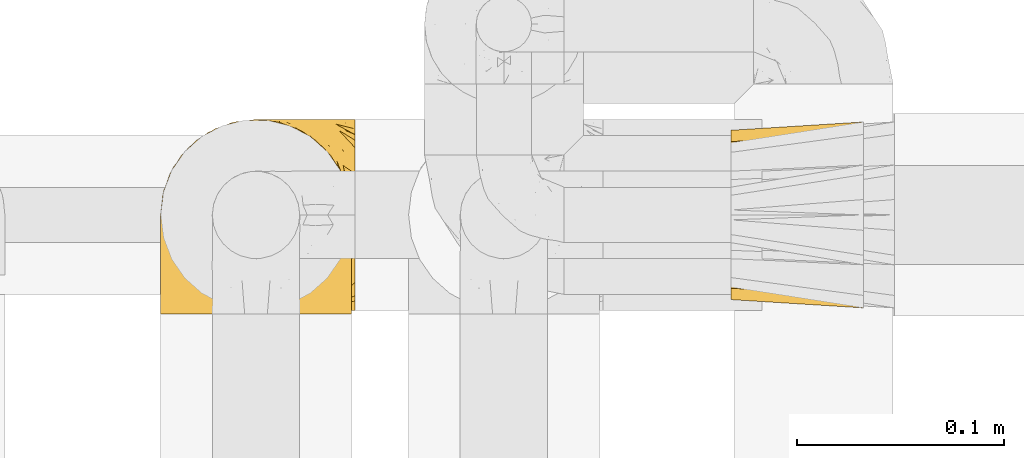
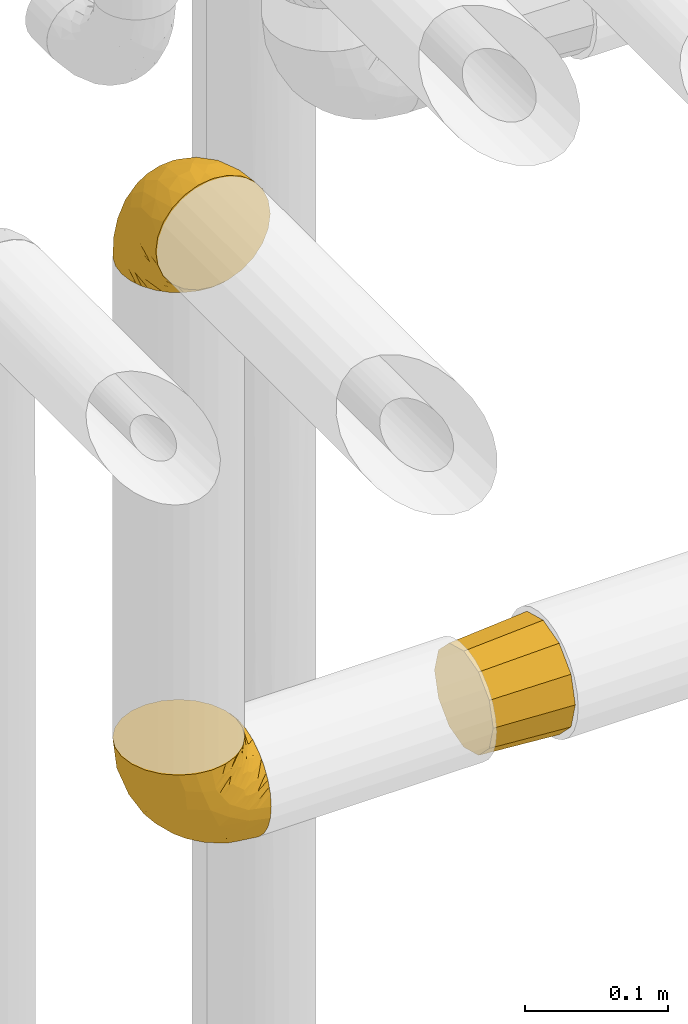
# One storey, part 431 of 827: 3 coverings.
"""IFC2X3 building model written with IfcOpenShell, lengths in millimetres."""

from ifc_helpers import new_model, entity, si_unit, converted_unit, derived_unit, direction, frame, origin, place, context, subcontext, project, spatial, faceted_brep, element, save


model = new_model("IFC2X3")

# Units and contexts
model_context = context("Model", 3, precision=0.01, world=origin(), true_north=direction((6.12303176911189e-17, 1.0)))
body_context = subcontext(model_context, "Body", "Model", "MODEL_VIEW")
ifc_project = project(units=[si_unit("LENGTHUNIT", "METRE", prefix="MILLI"), si_unit("AREAUNIT", "SQUARE_METRE"), si_unit("VOLUMEUNIT", "CUBIC_METRE"), converted_unit("PLANEANGLEUNIT", "DEGREE", entity("IfcRatioMeasure", 0.0174532925199433), si_unit("PLANEANGLEUNIT", "RADIAN"), dimensions=[0, 0, 0, 0, 0, 0, 0]), si_unit("MASSUNIT", "GRAM", prefix="KILO"), derived_unit("MASSDENSITYUNIT", [(si_unit("MASSUNIT", "GRAM", prefix="KILO"), 1), (si_unit("LENGTHUNIT", "METRE"), -3)]), derived_unit("MOMENTOFINERTIAUNIT", [(si_unit("LENGTHUNIT", "METRE"), 4)]), si_unit("TIMEUNIT", "SECOND"), si_unit("FREQUENCYUNIT", "HERTZ"), si_unit("THERMODYNAMICTEMPERATUREUNIT", "DEGREE_CELSIUS"), derived_unit("THERMALTRANSMITTANCEUNIT", [(si_unit("MASSUNIT", "GRAM", prefix="KILO"), 1), (si_unit("THERMODYNAMICTEMPERATUREUNIT", "KELVIN"), -1), (si_unit("TIMEUNIT", "SECOND"), -3)]), derived_unit("VOLUMETRICFLOWRATEUNIT", [(si_unit("LENGTHUNIT", "METRE"), 3), (si_unit("TIMEUNIT", "SECOND"), -1)]), derived_unit("MASSFLOWRATEUNIT", [(si_unit("MASSUNIT", "GRAM", prefix="KILO"), 1), (si_unit("TIMEUNIT", "SECOND"), -1)]), derived_unit("ROTATIONALFREQUENCYUNIT", [(si_unit("TIMEUNIT", "SECOND"), -1)]), si_unit("ELECTRICCURRENTUNIT", "AMPERE"), si_unit("ELECTRICVOLTAGEUNIT", "VOLT"), si_unit("POWERUNIT", "WATT"), si_unit("FORCEUNIT", "NEWTON", prefix="KILO"), si_unit("ILLUMINANCEUNIT", "LUX"), si_unit("LUMINOUSFLUXUNIT", "LUMEN"), si_unit("LUMINOUSINTENSITYUNIT", "CANDELA"), derived_unit("USERDEFINED", [(si_unit("MASSUNIT", "GRAM", prefix="KILO"), -1), (si_unit("LENGTHUNIT", "METRE"), -2), (si_unit("TIMEUNIT", "SECOND"), 3), (si_unit("LUMINOUSFLUXUNIT", "LUMEN"), 1)]), derived_unit("LINEARVELOCITYUNIT", [(si_unit("LENGTHUNIT", "METRE"), 1), (si_unit("TIMEUNIT", "SECOND"), -1)]), si_unit("PRESSUREUNIT", "PASCAL"), derived_unit("USERDEFINED", [(si_unit("LENGTHUNIT", "METRE"), -2), (si_unit("MASSUNIT", "GRAM", prefix="KILO"), 1), (si_unit("TIMEUNIT", "SECOND"), -2)]), derived_unit("LINEARFORCEUNIT", [(si_unit("MASSUNIT", "GRAM", prefix="KILO"), 1), (si_unit("LENGTHUNIT", "METRE"), 1), (si_unit("TIMEUNIT", "SECOND"), -2), (si_unit("LENGTHUNIT", "METRE"), -1)]), derived_unit("PLANARFORCEUNIT", [(si_unit("MASSUNIT", "GRAM", prefix="KILO"), 1), (si_unit("LENGTHUNIT", "METRE"), 1), (si_unit("TIMEUNIT", "SECOND"), -2), (si_unit("LENGTHUNIT", "METRE"), -2)])], contexts=[model_context])

# Site, building, storey
site_placement = place(None, origin())
site = spatial("IfcSite", under=ifc_project, at=site_placement, CompositionType="ELEMENT")
building_placement = place(site_placement, origin())
building = spatial("IfcBuilding", under=site, at=building_placement, CompositionType="ELEMENT")
storey_placement = place(building_placement, frame((0.0, 0.0, 28200.0)))
storey = spatial("IfcBuildingStorey", under=building, at=storey_placement, Name="08", CompositionType="ELEMENT", Elevation=28200.0)

# Coverings
covering_1_placement = place(storey_placement, frame((54021.99, 17450.4, 2450.4)))
element("IfcCovering", 1, at=covering_1_placement, inside=storey, Name=":ADSK_", ObjectType=":ADSK_", PredefinedType="INSULATION", context=body_context, shape_type="Brep", body=[
    faceted_brep([(11.68, 78.41, 1.6), (19.0, 85.72, 1.6), (27.76, 91.22, 1.6), (37.52, 94.64, 1.6), (47.8, 95.8, 1.6), (58.08, 94.64, 1.6), (67.85, 91.22, 1.6), (76.61, 85.71, 1.6), (83.92, 78.39, 1.6), (89.42, 69.63, 1.6), (92.84, 59.87, 1.6), (94.0, 49.6, 1.6), (93.53, 45.45, 1.6), (93.18, 42.38, 1.6), (92.84, 39.31, 1.6), (91.13, 34.43, 1.6), (89.42, 29.54, 1.6), (86.66, 25.16, 1.6), (83.91, 20.78, 1.6), (80.25, 17.13, 1.6), (76.59, 13.47, 1.6), (67.83, 7.97, 1.6), (62.95, 6.26, 1.6), (58.07, 4.55, 1.6), (47.8, 3.4, 1.6), (37.51, 4.55, 1.6), (32.63, 6.26, 1.6), (27.74, 7.97, 1.6), (18.98, 13.48, 1.6), (15.33, 17.14, 1.6), (11.67, 20.8, 1.6), (8.92, 25.18, 1.6), (6.17, 29.56, 1.6), (4.46, 34.44, 1.6), (2.75, 39.32, 1.6), (2.41, 42.39, 1.6), (2.06, 45.45, 1.6), (1.6, 49.6, 1.6), (2.75, 59.88, 1.6), (6.17, 69.65, 1.6), (47.8, 1.6, 3.4), (59.75, 1.6, 4.97), (70.9, 1.6, 9.58), (75.68, 1.6, 13.26), (80.46, 1.6, 16.93), (84.13, 1.6, 21.71), (87.81, 1.6, 26.5), (90.11, 1.6, 32.07), (92.42, 1.6, 37.64), (92.9, 1.6, 41.25), (93.17, 1.6, 43.34), (93.45, 1.6, 45.42), (94.0, 1.6, 49.6), (92.42, 1.6, 61.55), (87.81, 1.6, 72.7), (80.46, 1.6, 82.26), (70.9, 1.6, 89.61), (59.75, 1.6, 94.22), (47.8, 1.6, 95.8), (35.84, 1.6, 94.22), (24.7, 1.6, 89.61), (15.13, 1.6, 82.26), (7.78, 1.6, 72.7), (3.17, 1.6, 61.55), (1.6, 1.6, 49.6), (2.14, 1.6, 45.42), (2.69, 1.6, 41.25), (3.17, 1.6, 37.64), (5.48, 1.6, 32.07), (7.78, 1.6, 26.5), (11.46, 1.6, 21.71), (15.13, 1.6, 16.93), (19.91, 1.6, 13.26), (24.7, 1.6, 9.58), (35.84, 1.6, 4.97), (23.61, 36.81, 81.55), (31.99, 23.28, 90.4), (35.87, 45.8, 83.0), (47.8, 30.7, 91.18), (40.43, 21.2, 93.13), (47.8, 12.96, 94.0), (31.83, 66.19, 66.19), (23.37, 54.51, 70.92), (21.41, 17.98, 85.95), (3.07, 36.69, 49.74), (1.6, 35.54, 35.54), (1.6, 31.64, 38.14), (1.6, 27.75, 40.74), (1.6, 23.86, 43.34), (1.6, 19.96, 45.94), (13.45, 22.8, 77.59), (15.25, 42.67, 71.17), (8.07, 33.21, 65.81), (16.0, 59.45, 59.03), (17.34, 71.5, 45.85), (10.58, 62.66, 45.79), (5.34, 54.5, 41.42), (2.39, 47.57, 34.51), (8.36, 48.81, 56.04), (10.04, 74.98, 15.15), (2.59, 18.7, 56.51), (6.28, 15.75, 68.39), (34.28, 91.17, 23.33), (38.73, 85.28, 42.86), (27.25, 82.58, 39.42), (29.88, 75.78, 53.58), (38.6, 74.98, 59.17), (23.44, 67.27, 59.06), (25.25, 87.38, 22.63), (17.23, 82.04, 20.55), (47.8, 94.0, 12.96), (47.8, 77.8, 56.96), (47.8, 67.38, 67.38), (2.53, 56.2, 18.72), (1.6, 48.85, 5.33), (1.6, 48.11, 9.07), (1.6, 47.57, 11.79), (1.6, 47.03, 14.51), (1.6, 46.48, 17.24), (1.6, 45.94, 19.96), (5.71, 65.78, 21.03), (1.6, 17.24, 46.48), (1.6, 14.51, 47.03), (1.6, 11.79, 47.57), (1.6, 9.07, 48.11), (1.6, 7.2, 48.48), (1.6, 5.33, 48.85), (47.8, 91.18, 30.7), (1.6, 43.34, 23.86), (1.6, 40.74, 27.75), (1.6, 38.14, 31.64), (11.89, 72.73, 31.26), (47.8, 56.96, 77.8), (39.69, 62.23, 72.75), (47.8, 84.49, 43.83), (47.8, 43.83, 84.49), (13.84, 12.05, 14.58), (9.16, 18.95, 16.17), (15.79, 13.02, 10.82), (25.75, 8.34, 4.64), (16.09, 14.63, 7.71), (7.51, 11.09, 25.13), (3.99, 13.66, 32.66), (2.66, 20.08, 34.94), (3.16, 9.61, 36.76), (2.35, 9.48, 40.48), (2.23, 16.1, 39.25), (38.35, 3.42, 3.69), (6.18, 26.63, 13.99), (2.7, 33.72, 21.85), (2.93, 34.77, 17.93), (16.01, 6.75, 15.11), (9.08, 13.31, 21.14), (9.3, 21.11, 12.7), (11.68, 19.94, 7.21), (4.65, 8.67, 32.27), (3.65, 26.11, 25.68), (3.61, 29.3, 22.18), (12.8, 6.32, 18.79), (2.43, 39.92, 10.12), (6.83, 27.05, 9.47), (21.65, 6.04, 10.45), (3.7, 34.4, 11.29), (47.8, 2.87, 2.87), (3.37, 20.92, 31.16), (7.03, 27.43, 6.31), (7.87, 7.54, 25.62), (7.26, 18.45, 21.18), (3.41, 23.88, 28.81), (23.81, 7.77, 7.45), (86.5, 13.3, 21.14), (88.08, 11.09, 25.13), (82.79, 6.33, 18.79), (94.0, 9.07, 48.11), (94.0, 5.33, 48.85), (94.0, 14.51, 47.03), (94.0, 11.79, 47.57), (57.24, 3.42, 3.69), (71.76, 7.76, 7.44), (94.0, 47.03, 14.51), (94.0, 47.57, 11.79), (94.0, 48.85, 5.33), (94.0, 48.11, 9.07), (79.49, 14.62, 7.71), (88.75, 27.03, 9.47), (92.93, 20.08, 34.94), (92.22, 20.92, 31.16), (94.0, 27.75, 40.74), (94.0, 31.64, 38.14), (92.43, 9.61, 36.76), (93.24, 9.48, 40.48), (69.82, 8.33, 4.63), (79.57, 6.74, 15.11), (81.74, 12.04, 14.58), (94.0, 23.86, 43.34), (94.0, 19.96, 45.94), (93.36, 16.1, 39.25), (83.9, 19.93, 7.21), (86.28, 21.1, 12.69), (93.16, 39.92, 10.14), (92.88, 33.68, 21.81), (91.98, 29.28, 22.19), (89.41, 26.62, 14.0), (91.93, 26.08, 25.69), (86.42, 18.93, 16.17), (88.82, 27.87, 6.66), (92.66, 34.75, 17.92), (73.93, 6.04, 10.45), (94.0, 38.14, 31.64), (79.5, 12.79, 10.64), (91.89, 34.41, 11.31), (94.0, 45.94, 19.96), (94.0, 43.34, 23.86), (94.0, 40.74, 27.75), (91.6, 13.66, 32.66), (94.0, 17.24, 46.48), (90.94, 8.67, 32.27), (94.0, 35.54, 35.54), (92.16, 23.83, 28.77), (88.32, 18.43, 21.17), (86.13, 6.03, 23.36), (94.0, 46.48, 17.24), (93.2, 34.52, 47.58), (55.16, 21.2, 93.13), (82.02, 23.82, 77.44), (84.29, 41.32, 66.78), (76.94, 47.62, 71.68), (68.33, 52.66, 74.96), (71.98, 36.81, 81.55), (92.52, 49.75, 36.7), (92.9, 19.07, 56.9), (59.72, 45.8, 83.0), (63.6, 23.28, 90.4), (88.89, 21.35, 67.83), (74.18, 17.98, 85.95), (68.35, 82.57, 39.41), (61.33, 91.17, 23.33), (56.86, 85.27, 42.87), (68.62, 73.89, 53.92), (63.76, 66.19, 66.19), (72.19, 62.43, 64.12), (88.69, 63.53, 33.13), (92.19, 58.45, 23.1), (89.75, 67.16, 16.98), (59.86, 76.72, 55.72), (55.9, 62.22, 72.75), (77.99, 81.54, 23.77), (85.21, 74.8, 18.41), (74.99, 75.83, 43.7), (90.23, 41.45, 54.53), (70.75, 88.2, 17.73), (81.72, 71.6, 38.98), (86.53, 56.23, 50.28), (79.6, 59.44, 59.02)], [[[0, 1, 2, 3, 4, 5, 6, 7, 8, 9, 10, 11, 12, 13, 14, 15, 16, 17, 18, 19, 20, 21, 22, 23, 24, 25, 26, 27, 28, 29, 30, 31, 32, 33, 34, 35, 36, 37, 38, 39]], [[40, 41, 42, 43, 44, 45, 46, 47, 48, 49, 50, 51, 52, 53, 54, 55, 56, 57, 58, 59, 60, 61, 62, 63, 64, 65, 66, 67, 68, 69, 70, 71, 72, 73, 74]], [[75, 76, 77]], [[78, 79, 80]], [[77, 81, 82]], [[76, 75, 83]], [[84, 85, 86, 87, 88, 89]], [[90, 91, 92]], [[76, 60, 59]], [[93, 94, 95]], [[90, 62, 61]], [[83, 61, 60]], [[96, 97, 84]], [[98, 93, 95]], [[0, 39, 99]], [[100, 84, 89]], [[62, 101, 63]], [[2, 102, 3]], [[92, 84, 100]], [[103, 102, 104]], [[103, 105, 106]], [[93, 107, 94]], [[1, 108, 2]], [[92, 101, 90]], [[108, 1, 109]], [[102, 110, 3]], [[93, 82, 107]], [[102, 108, 104]], [[111, 106, 112]], [[109, 0, 99]], [[113, 37, 114, 115, 116, 117, 118, 119]], [[120, 38, 113]], [[100, 89, 121, 122, 123, 124, 125, 126, 64]], [[127, 102, 103]], [[97, 119, 128, 129, 130, 85]], [[99, 120, 131]], [[132, 133, 77]], [[59, 80, 79]], [[1, 0, 109]], [[98, 84, 92]], [[94, 109, 131]], [[120, 39, 38]], [[93, 91, 82]], [[104, 94, 105]], [[97, 113, 119]], [[95, 120, 96]], [[83, 90, 61]], [[91, 93, 98]], [[64, 63, 100]], [[100, 63, 101]], [[77, 76, 79]], [[133, 106, 81]], [[84, 97, 85]], [[113, 96, 120]], [[113, 97, 96]], [[37, 113, 38]], [[110, 102, 127]], [[110, 4, 3]], [[103, 111, 134, 127]], [[90, 75, 91]], [[82, 81, 107]], [[91, 75, 82]], [[77, 82, 75]], [[76, 83, 60]], [[90, 83, 75]], [[105, 107, 81]], [[94, 131, 95]], [[105, 94, 107]], [[109, 94, 104]], [[120, 95, 131]], [[98, 95, 96]], [[84, 98, 96]], [[98, 92, 91]], [[106, 105, 81]], [[103, 104, 105]], [[112, 106, 133]], [[103, 106, 111]], [[112, 133, 132]], [[81, 77, 133]], [[77, 78, 135, 132]], [[120, 99, 39]], [[109, 99, 131]], [[59, 58, 80]], [[59, 79, 76]], [[90, 101, 62]], [[100, 101, 92]], [[2, 108, 102]], [[109, 104, 108]], [[78, 77, 79]], [[136, 137, 138]], [[27, 139, 140]], [[141, 142, 143]], [[144, 145, 121]], [[146, 89, 88]], [[147, 139, 25]], [[148, 149, 150]], [[136, 151, 152]], [[147, 40, 74]], [[24, 147, 25]], [[140, 153, 154]], [[33, 116, 34]], [[73, 72, 151]], [[114, 37, 36, 35, 34, 116, 115]], [[146, 155, 144]], [[156, 85, 130]], [[157, 149, 148]], [[151, 158, 152]], [[117, 33, 159]], [[29, 154, 160]], [[161, 74, 73]], [[162, 128, 119]], [[66, 65, 64, 126, 125, 124, 123, 122, 67]], [[163, 147, 24]], [[27, 140, 28]], [[149, 129, 150]], [[139, 27, 26, 25]], [[68, 144, 69]], [[129, 128, 150]], [[164, 87, 86]], [[130, 129, 149]], [[122, 145, 67]], [[154, 153, 148]], [[162, 119, 159]], [[165, 30, 160]], [[150, 160, 148]], [[128, 162, 150]], [[30, 165, 31]], [[145, 144, 68]], [[89, 146, 144]], [[87, 164, 143]], [[166, 155, 142]], [[88, 87, 143]], [[162, 160, 150]], [[160, 30, 29]], [[154, 29, 28]], [[140, 154, 28]], [[160, 154, 148]], [[140, 137, 153]], [[157, 148, 153]], [[156, 130, 157]], [[153, 137, 157]], [[157, 137, 156]], [[167, 137, 136]], [[168, 85, 156]], [[152, 168, 167]], [[167, 168, 156]], [[164, 152, 141]], [[71, 158, 72]], [[152, 167, 136]], [[88, 142, 146]], [[144, 155, 69]], [[146, 142, 155]], [[70, 166, 71]], [[142, 141, 166]], [[70, 69, 155]], [[141, 158, 71]], [[161, 73, 151]], [[138, 137, 140]], [[161, 136, 169]], [[136, 161, 151]], [[74, 161, 169]], [[152, 158, 141]], [[151, 72, 158]], [[168, 152, 164]], [[137, 167, 156]], [[164, 86, 168]], [[85, 168, 86]], [[116, 33, 117]], [[130, 149, 157]], [[67, 145, 68]], [[121, 89, 144]], [[145, 122, 121]], [[40, 147, 163]], [[169, 147, 74]], [[159, 33, 32]], [[162, 159, 32]], [[159, 119, 118, 117]], [[139, 147, 169]], [[139, 169, 138]], [[162, 32, 31]], [[141, 143, 164]], [[88, 143, 142]], [[71, 166, 141]], [[155, 166, 70]], [[139, 138, 140]], [[169, 136, 138]], [[160, 162, 165]], [[162, 31, 165]], [[170, 171, 172]], [[173, 174, 52, 51, 50, 49, 48, 175, 176]], [[177, 178, 41]], [[179, 15, 180]], [[12, 11, 181, 182, 180, 14, 13]], [[183, 21, 20]], [[19, 18, 184]], [[185, 186, 187]], [[186, 188, 187]], [[43, 172, 44]], [[189, 190, 47]], [[23, 22, 21, 191]], [[170, 192, 193]], [[40, 163, 177]], [[194, 195, 196]], [[24, 23, 177]], [[197, 198, 183]], [[199, 15, 179]], [[47, 46, 189]], [[200, 201, 202]], [[201, 203, 204]], [[205, 206, 184]], [[207, 41, 178]], [[16, 15, 199]], [[14, 180, 15]], [[202, 201, 198]], [[208, 201, 200]], [[163, 24, 177]], [[48, 47, 190]], [[196, 195, 189]], [[197, 184, 202]], [[204, 193, 209]], [[210, 211, 212]], [[206, 212, 213]], [[205, 17, 210]], [[184, 206, 202]], [[210, 212, 206]], [[185, 194, 214]], [[189, 215, 190]], [[216, 45, 214]], [[186, 171, 170]], [[189, 216, 196]], [[197, 20, 19]], [[194, 185, 187]], [[197, 183, 20]], [[184, 197, 19]], [[197, 202, 198]], [[206, 200, 202]], [[204, 183, 198]], [[201, 208, 203]], [[203, 208, 217]], [[204, 198, 201]], [[217, 188, 218]], [[193, 219, 170]], [[171, 186, 185]], [[170, 218, 186]], [[170, 219, 218]], [[42, 207, 192]], [[171, 220, 172]], [[216, 189, 46]], [[214, 194, 196]], [[44, 220, 45]], [[214, 196, 216]], [[216, 46, 45]], [[214, 45, 220]], [[192, 43, 42]], [[204, 203, 219]], [[207, 193, 192]], [[209, 193, 178]], [[41, 207, 42]], [[193, 207, 178]], [[43, 192, 172]], [[170, 172, 192]], [[204, 219, 193]], [[219, 203, 218]], [[217, 218, 203]], [[188, 186, 218]], [[206, 213, 200]], [[208, 200, 213]], [[199, 210, 16]], [[215, 189, 195]], [[215, 175, 190]], [[175, 48, 190]], [[199, 179, 221, 211]], [[210, 199, 211]], [[23, 191, 177]], [[40, 177, 41]], [[178, 177, 191]], [[21, 183, 191]], [[209, 191, 183]], [[205, 18, 17]], [[17, 16, 210]], [[171, 185, 214]], [[172, 220, 44]], [[214, 220, 171]], [[191, 209, 178]], [[204, 209, 183]], [[206, 205, 210]], [[18, 205, 184]], [[222, 195, 194, 187, 188, 217]], [[57, 223, 80]], [[224, 225, 226]], [[226, 227, 228]], [[229, 217, 208, 213, 212, 211]], [[230, 52, 174, 173, 176, 175, 215, 195]], [[231, 232, 228]], [[231, 78, 223]], [[223, 57, 232]], [[224, 233, 225]], [[233, 54, 53]], [[234, 232, 56]], [[56, 55, 234]], [[234, 224, 228]], [[235, 236, 237]], [[224, 55, 54]], [[238, 239, 240]], [[52, 230, 53]], [[241, 242, 243]], [[239, 244, 245]], [[11, 10, 242]], [[236, 6, 5]], [[7, 246, 8]], [[8, 247, 9]], [[238, 248, 235]], [[222, 229, 249]], [[242, 211, 221, 179, 180, 182, 181, 11]], [[233, 53, 230]], [[111, 112, 244]], [[250, 6, 236]], [[247, 251, 241]], [[6, 250, 7]], [[127, 236, 110]], [[249, 229, 252]], [[247, 8, 246]], [[235, 246, 250]], [[236, 5, 110]], [[235, 244, 238]], [[237, 236, 127]], [[243, 9, 247]], [[252, 229, 241]], [[56, 232, 57]], [[222, 230, 195]], [[225, 249, 252]], [[249, 233, 230]], [[54, 233, 224]], [[231, 228, 227]], [[245, 132, 231]], [[249, 225, 233]], [[226, 225, 253]], [[235, 250, 236]], [[246, 7, 250]], [[251, 247, 246]], [[243, 247, 241]], [[248, 246, 235]], [[252, 251, 253]], [[229, 222, 217]], [[230, 222, 249]], [[5, 4, 110]], [[237, 127, 134, 111]], [[238, 244, 239]], [[224, 234, 55]], [[232, 234, 228]], [[242, 241, 229]], [[10, 9, 243]], [[211, 242, 229]], [[10, 243, 242]], [[80, 223, 78]], [[80, 58, 57]], [[231, 223, 232]], [[227, 240, 239]], [[224, 226, 228]], [[240, 226, 253]], [[227, 239, 245]], [[226, 240, 227]], [[251, 248, 253]], [[240, 253, 248]], [[244, 235, 237]], [[237, 111, 244]], [[132, 245, 112]], [[112, 245, 244]], [[135, 78, 231, 132]], [[227, 245, 231]], [[248, 238, 240]], [[246, 248, 251]], [[251, 252, 241]], [[225, 252, 253]]]),
])
covering_2_placement = place(storey_placement, frame((54021.99, 17452.2, 1944.7)))
element("IfcCovering", 2, at=covering_2_placement, inside=storey, Name=":ADSK_", ObjectType=":ADSK_", PredefinedType="INSULATION", context=body_context, shape_type="Brep", body=[
    faceted_brep([(95.8, 11.68, 18.98), (95.8, 19.0, 11.67), (95.8, 27.76, 6.17), (95.8, 37.52, 2.75), (95.8, 47.8, 1.6), (95.8, 58.08, 2.75), (95.8, 67.85, 6.17), (95.8, 76.61, 11.68), (95.8, 83.92, 19.0), (95.8, 89.42, 27.76), (95.8, 92.84, 37.52), (95.8, 94.0, 47.8), (95.8, 93.53, 51.94), (95.8, 93.18, 55.01), (95.8, 92.84, 58.08), (95.8, 91.13, 62.96), (95.8, 89.42, 67.85), (95.8, 86.66, 72.23), (95.8, 83.91, 76.61), (95.8, 80.25, 80.26), (95.8, 76.59, 83.92), (95.8, 67.83, 89.42), (95.8, 62.95, 91.13), (95.8, 58.07, 92.84), (95.8, 47.8, 94.0), (95.8, 37.51, 92.84), (95.8, 32.63, 91.13), (95.8, 27.74, 89.42), (95.8, 18.98, 83.91), (95.8, 15.33, 80.25), (95.8, 11.67, 76.59), (95.8, 8.92, 72.21), (95.8, 6.17, 67.83), (95.8, 4.46, 62.95), (95.8, 2.75, 58.07), (95.8, 2.41, 55.0), (95.8, 2.06, 51.94), (95.8, 1.6, 47.8), (95.8, 2.75, 37.51), (95.8, 6.17, 27.74), (94.0, 47.8, 95.8), (92.42, 59.75, 95.8), (87.81, 70.9, 95.8), (84.13, 75.68, 95.8), (80.46, 80.46, 95.8), (75.68, 84.13, 95.8), (70.9, 87.81, 95.8), (65.32, 90.11, 95.8), (59.75, 92.42, 95.8), (56.14, 92.9, 95.8), (54.06, 93.17, 95.8), (51.97, 93.45, 95.8), (47.8, 94.0, 95.8), (35.84, 92.42, 95.8), (24.7, 87.81, 95.8), (15.13, 80.46, 95.8), (7.78, 70.9, 95.8), (3.17, 59.75, 95.8), (1.6, 47.8, 95.8), (3.17, 35.84, 95.8), (7.78, 24.7, 95.8), (15.13, 15.13, 95.8), (24.7, 7.78, 95.8), (35.84, 3.17, 95.8), (47.8, 1.6, 95.8), (51.97, 2.14, 95.8), (56.14, 2.69, 95.8), (59.75, 3.17, 95.8), (65.32, 5.48, 95.8), (70.9, 7.78, 95.8), (75.68, 11.46, 95.8), (80.46, 15.13, 95.8), (84.13, 19.91, 95.8), (87.81, 24.7, 95.8), (92.42, 35.84, 95.8), (15.84, 23.61, 60.58), (6.99, 31.99, 74.11), (14.39, 35.87, 51.59), (6.21, 47.8, 66.69), (4.26, 40.43, 76.19), (3.39, 47.8, 84.43), (31.2, 31.83, 31.2), (26.47, 23.37, 42.88), (11.44, 21.41, 79.41), (47.66, 3.07, 60.7), (61.85, 1.6, 61.85), (59.25, 1.6, 65.75), (56.65, 1.6, 69.64), (54.05, 1.6, 73.53), (51.45, 1.6, 77.43), (19.8, 13.45, 74.59), (26.22, 15.25, 54.72), (31.58, 8.07, 64.18), (38.36, 16.0, 37.94), (51.54, 17.34, 25.89), (51.6, 10.58, 34.73), (55.97, 5.34, 42.89), (62.88, 2.39, 49.83), (41.35, 8.36, 48.58), (82.24, 10.04, 22.41), (40.88, 2.59, 78.69), (29.0, 6.28, 81.64), (74.06, 34.28, 6.22), (54.53, 38.73, 12.11), (57.98, 27.25, 14.81), (43.81, 29.88, 21.61), (38.22, 38.6, 22.41), (38.33, 23.44, 30.12), (74.76, 25.25, 10.01), (76.85, 17.23, 15.36), (84.43, 47.8, 3.39), (40.43, 47.8, 19.59), (30.01, 47.8, 30.01), (78.67, 2.53, 41.19), (92.06, 1.6, 48.54), (88.32, 1.6, 49.28), (85.6, 1.6, 49.82), (82.88, 1.6, 50.37), (80.15, 1.6, 50.91), (77.43, 1.6, 51.45), (76.36, 5.71, 31.61), (50.91, 1.6, 80.15), (50.37, 1.6, 82.88), (49.82, 1.6, 85.6), (49.28, 1.6, 88.32), (48.91, 1.6, 90.19), (48.54, 1.6, 92.06), (66.69, 47.8, 6.21), (73.53, 1.6, 54.05), (69.64, 1.6, 56.65), (65.75, 1.6, 59.25), (66.13, 11.89, 24.66), (19.59, 47.8, 40.43), (24.64, 39.69, 35.17), (53.56, 47.8, 12.9), (12.9, 47.8, 53.56), (82.81, 13.84, 85.34), (81.22, 9.16, 78.44), (86.57, 15.79, 84.37), (92.75, 25.75, 89.05), (89.68, 16.09, 82.76), (72.26, 7.51, 86.31), (64.73, 3.99, 83.73), (62.45, 2.66, 77.31), (60.63, 3.16, 87.78), (56.91, 2.35, 87.91), (58.14, 2.23, 81.29), (93.7, 38.35, 93.97), (83.4, 6.18, 70.76), (75.54, 2.7, 63.67), (79.46, 2.93, 62.62), (82.28, 16.01, 90.64), (76.25, 9.08, 84.08), (90.18, 11.68, 77.45), (84.69, 9.3, 76.28), (86.94, 21.65, 91.35), (65.12, 4.65, 88.72), (71.71, 3.65, 71.28), (75.21, 3.61, 68.09), (78.6, 12.8, 91.07), (87.27, 2.43, 57.47), (87.92, 6.83, 70.34), (86.1, 3.7, 62.99), (94.52, 47.8, 94.52), (66.23, 3.37, 76.47), (91.08, 7.03, 69.96), (71.77, 7.87, 89.86), (76.21, 7.26, 78.94), (68.59, 3.41, 73.51), (89.94, 23.81, 89.62), (76.22, 88.32, 78.96), (81.22, 86.42, 78.46), (71.7, 91.93, 71.31), (49.28, 94.0, 88.32), (48.54, 94.0, 92.06), (50.37, 94.0, 82.88), (49.82, 94.0, 85.6), (93.7, 57.24, 93.97), (89.95, 71.76, 89.63), (82.88, 94.0, 50.37), (85.6, 94.0, 49.82), (92.06, 94.0, 48.54), (88.32, 94.0, 49.28), (89.68, 79.49, 82.77), (87.92, 88.75, 70.36), (62.45, 92.93, 77.31), (66.24, 92.22, 76.47), (56.65, 94.0, 69.64), (59.25, 94.0, 65.75), (78.6, 82.79, 91.06), (60.63, 92.43, 87.78), (56.91, 93.24, 87.91), (92.76, 69.82, 89.06), (76.25, 86.5, 84.09), (82.28, 79.57, 90.65), (82.81, 81.74, 85.35), (54.05, 94.0, 73.53), (51.45, 94.0, 77.43), (58.14, 93.36, 81.29), (90.18, 83.9, 77.46), (84.7, 86.28, 76.29), (87.25, 93.16, 57.47), (75.58, 92.88, 63.71), (75.2, 91.98, 68.11), (83.39, 89.41, 70.77), (90.73, 88.82, 69.52), (79.47, 92.66, 62.64), (86.94, 73.93, 91.35), (65.75, 94.0, 59.25), (86.75, 79.5, 84.6), (86.08, 91.89, 62.98), (77.43, 94.0, 51.45), (73.53, 94.0, 54.05), (69.64, 94.0, 56.65), (64.73, 91.6, 83.73), (50.91, 94.0, 80.15), (65.12, 90.94, 88.72), (72.26, 88.08, 86.3), (61.85, 94.0, 61.85), (68.62, 92.16, 73.56), (74.03, 86.13, 91.36), (80.15, 94.0, 50.91), (49.81, 93.2, 62.87), (4.26, 55.16, 76.19), (19.95, 82.02, 73.57), (30.61, 84.29, 56.07), (25.71, 76.94, 49.77), (22.43, 68.33, 44.73), (15.85, 71.98, 60.58), (60.69, 92.52, 47.64), (40.49, 92.9, 78.32), (14.39, 59.72, 51.59), (6.99, 63.6, 74.11), (29.56, 88.89, 76.04), (11.45, 74.18, 79.41), (57.98, 68.35, 14.82), (74.06, 61.33, 6.22), (54.52, 56.86, 12.12), (43.47, 68.62, 23.51), (31.2, 63.76, 31.2), (33.27, 72.19, 34.96), (64.26, 88.69, 33.86), (74.29, 92.19, 38.94), (80.41, 89.75, 30.23), (41.67, 59.86, 20.67), (24.64, 55.9, 35.17), (73.62, 77.99, 15.85), (78.98, 85.21, 22.59), (53.69, 74.99, 21.56), (42.86, 90.23, 55.94), (79.66, 70.75, 9.19), (58.41, 81.72, 25.79), (47.11, 86.53, 41.16), (38.37, 79.6, 37.95)], [[[0, 1, 2, 3, 4, 5, 6, 7, 8, 9, 10, 11, 12, 13, 14, 15, 16, 17, 18, 19, 20, 21, 22, 23, 24, 25, 26, 27, 28, 29, 30, 31, 32, 33, 34, 35, 36, 37, 38, 39]], [[40, 41, 42, 43, 44, 45, 46, 47, 48, 49, 50, 51, 52, 53, 54, 55, 56, 57, 58, 59, 60, 61, 62, 63, 64, 65, 66, 67, 68, 69, 70, 71, 72, 73, 74]], [[75, 76, 77]], [[78, 79, 80]], [[77, 81, 82]], [[76, 75, 83]], [[84, 85, 86, 87, 88, 89]], [[90, 91, 92]], [[76, 60, 59]], [[93, 94, 95]], [[90, 62, 61]], [[83, 61, 60]], [[96, 97, 84]], [[98, 93, 95]], [[0, 39, 99]], [[100, 84, 89]], [[62, 101, 63]], [[2, 102, 3]], [[92, 84, 100]], [[103, 102, 104]], [[103, 105, 106]], [[93, 107, 94]], [[1, 108, 2]], [[92, 101, 90]], [[108, 1, 109]], [[102, 110, 3]], [[93, 82, 107]], [[102, 108, 104]], [[111, 106, 112]], [[109, 0, 99]], [[113, 37, 114, 115, 116, 117, 118, 119]], [[120, 38, 113]], [[100, 89, 121, 122, 123, 124, 125, 126, 64]], [[127, 102, 103]], [[97, 119, 128, 129, 130, 85]], [[99, 120, 131]], [[132, 133, 77]], [[59, 80, 79]], [[1, 0, 109]], [[98, 84, 92]], [[94, 109, 131]], [[120, 39, 38]], [[93, 91, 82]], [[104, 94, 105]], [[97, 113, 119]], [[95, 120, 96]], [[83, 90, 61]], [[91, 93, 98]], [[64, 63, 100]], [[100, 63, 101]], [[77, 76, 79]], [[133, 106, 81]], [[84, 97, 85]], [[113, 96, 120]], [[113, 97, 96]], [[37, 113, 38]], [[110, 102, 127]], [[110, 4, 3]], [[103, 111, 134, 127]], [[90, 75, 91]], [[82, 81, 107]], [[91, 75, 82]], [[77, 82, 75]], [[76, 83, 60]], [[90, 83, 75]], [[105, 107, 81]], [[94, 131, 95]], [[105, 94, 107]], [[109, 94, 104]], [[120, 95, 131]], [[98, 95, 96]], [[84, 98, 96]], [[98, 92, 91]], [[106, 105, 81]], [[103, 104, 105]], [[112, 106, 133]], [[103, 106, 111]], [[112, 133, 132]], [[81, 77, 133]], [[77, 78, 135, 132]], [[120, 99, 39]], [[109, 99, 131]], [[59, 58, 80]], [[59, 79, 76]], [[90, 101, 62]], [[100, 101, 92]], [[2, 108, 102]], [[109, 104, 108]], [[78, 77, 79]], [[136, 137, 138]], [[27, 139, 140]], [[141, 142, 143]], [[144, 145, 121]], [[146, 89, 88]], [[147, 139, 25]], [[148, 149, 150]], [[136, 151, 152]], [[147, 40, 74]], [[24, 147, 25]], [[153, 140, 154]], [[33, 116, 34]], [[73, 151, 155]], [[114, 37, 36, 35, 34, 116, 115]], [[146, 156, 144]], [[157, 85, 130]], [[158, 149, 148]], [[151, 159, 152]], [[117, 33, 160]], [[29, 153, 161]], [[155, 74, 73]], [[162, 128, 119]], [[66, 65, 64, 126, 125, 124, 123, 122, 67]], [[163, 147, 24]], [[27, 140, 28]], [[149, 129, 150]], [[139, 27, 26, 25]], [[68, 144, 69]], [[129, 128, 150]], [[164, 87, 86]], [[130, 129, 149]], [[122, 145, 67]], [[153, 154, 148]], [[162, 119, 160]], [[165, 30, 161]], [[150, 161, 148]], [[128, 162, 150]], [[30, 165, 31]], [[145, 144, 68]], [[89, 146, 144]], [[87, 164, 143]], [[166, 156, 142]], [[88, 87, 143]], [[162, 161, 150]], [[161, 30, 29]], [[161, 153, 148]], [[28, 140, 153]], [[29, 28, 153]], [[140, 137, 154]], [[158, 148, 154]], [[157, 130, 158]], [[154, 137, 158]], [[158, 137, 157]], [[167, 137, 136]], [[168, 85, 157]], [[152, 168, 167]], [[167, 168, 157]], [[164, 152, 141]], [[151, 73, 72]], [[159, 72, 71]], [[88, 142, 146]], [[144, 156, 69]], [[146, 142, 156]], [[70, 166, 71]], [[142, 141, 166]], [[70, 69, 156]], [[141, 159, 71]], [[167, 136, 152]], [[138, 137, 140]], [[155, 136, 169]], [[136, 155, 151]], [[74, 155, 169]], [[152, 159, 141]], [[151, 72, 159]], [[168, 152, 164]], [[137, 167, 157]], [[164, 86, 168]], [[85, 168, 86]], [[116, 33, 117]], [[130, 149, 158]], [[67, 145, 68]], [[121, 89, 144]], [[145, 122, 121]], [[40, 147, 163]], [[169, 147, 74]], [[160, 33, 32]], [[162, 160, 32]], [[160, 119, 118, 117]], [[139, 147, 169]], [[139, 169, 138]], [[162, 32, 31]], [[141, 143, 164]], [[88, 143, 142]], [[71, 166, 141]], [[156, 166, 70]], [[139, 138, 140]], [[169, 136, 138]], [[161, 162, 165]], [[162, 31, 165]], [[170, 171, 172]], [[173, 174, 52, 51, 50, 49, 48, 175, 176]], [[177, 178, 41]], [[179, 15, 180]], [[12, 11, 181, 182, 180, 14, 13]], [[183, 21, 20]], [[19, 18, 184]], [[185, 186, 187]], [[186, 188, 187]], [[43, 189, 44]], [[190, 191, 47]], [[23, 22, 21, 192]], [[193, 194, 195]], [[40, 163, 177]], [[196, 197, 198]], [[24, 23, 177]], [[199, 200, 183]], [[201, 15, 179]], [[178, 177, 192]], [[47, 46, 190]], [[202, 203, 204]], [[203, 172, 171]], [[205, 206, 184]], [[207, 41, 178]], [[16, 15, 201]], [[14, 180, 15]], [[204, 203, 200]], [[208, 203, 202]], [[163, 24, 177]], [[48, 47, 191]], [[198, 197, 190]], [[199, 184, 204]], [[171, 195, 209]], [[210, 211, 212]], [[206, 212, 213]], [[205, 17, 210]], [[184, 206, 204]], [[210, 212, 206]], [[185, 196, 214]], [[190, 215, 191]], [[216, 45, 214]], [[186, 217, 193]], [[190, 216, 198]], [[199, 20, 19]], [[196, 185, 187]], [[199, 183, 20]], [[184, 199, 19]], [[199, 204, 200]], [[206, 202, 204]], [[171, 183, 200]], [[203, 208, 172]], [[172, 208, 218]], [[171, 200, 203]], [[218, 188, 219]], [[195, 170, 193]], [[217, 186, 185]], [[193, 219, 186]], [[193, 170, 219]], [[207, 194, 42]], [[217, 220, 189]], [[216, 190, 46]], [[214, 196, 198]], [[44, 220, 45]], [[214, 198, 216]], [[216, 46, 45]], [[214, 45, 220]], [[42, 194, 43]], [[189, 193, 217]], [[207, 195, 194]], [[209, 195, 178]], [[41, 207, 42]], [[195, 207, 178]], [[43, 194, 189]], [[193, 189, 194]], [[171, 170, 195]], [[170, 172, 219]], [[218, 219, 172]], [[188, 186, 219]], [[206, 213, 202]], [[208, 202, 213]], [[201, 210, 16]], [[215, 190, 197]], [[215, 175, 191]], [[175, 48, 191]], [[201, 179, 221, 211]], [[210, 201, 211]], [[23, 192, 177]], [[40, 177, 41]], [[192, 183, 209]], [[21, 183, 192]], [[205, 18, 17]], [[17, 16, 210]], [[217, 185, 214]], [[189, 220, 44]], [[214, 220, 217]], [[192, 209, 178]], [[171, 209, 183]], [[206, 205, 210]], [[18, 205, 184]], [[222, 197, 196, 187, 188, 218]], [[57, 223, 80]], [[224, 225, 226]], [[226, 227, 228]], [[229, 218, 208, 213, 212, 211]], [[230, 52, 174, 173, 176, 175, 215, 197]], [[231, 232, 228]], [[231, 78, 223]], [[223, 57, 232]], [[224, 233, 225]], [[233, 54, 53]], [[234, 232, 56]], [[56, 55, 234]], [[234, 224, 228]], [[235, 236, 237]], [[224, 55, 54]], [[238, 239, 240]], [[52, 230, 53]], [[241, 242, 243]], [[239, 244, 245]], [[11, 10, 242]], [[236, 6, 5]], [[7, 246, 8]], [[8, 247, 9]], [[238, 248, 235]], [[222, 229, 249]], [[242, 211, 221, 179, 180, 182, 181, 11]], [[233, 53, 230]], [[111, 112, 244]], [[250, 6, 236]], [[247, 251, 241]], [[6, 250, 7]], [[127, 236, 110]], [[249, 229, 252]], [[247, 8, 246]], [[235, 246, 250]], [[236, 5, 110]], [[235, 244, 238]], [[237, 236, 127]], [[243, 9, 247]], [[252, 229, 241]], [[56, 232, 57]], [[222, 230, 197]], [[225, 249, 252]], [[249, 233, 230]], [[54, 233, 224]], [[231, 228, 227]], [[245, 132, 231]], [[249, 225, 233]], [[226, 225, 253]], [[235, 250, 236]], [[246, 7, 250]], [[251, 247, 246]], [[243, 247, 241]], [[248, 246, 235]], [[252, 251, 253]], [[229, 222, 218]], [[230, 222, 249]], [[5, 4, 110]], [[237, 127, 134, 111]], [[238, 244, 239]], [[224, 234, 55]], [[232, 234, 228]], [[242, 241, 229]], [[10, 9, 243]], [[211, 242, 229]], [[10, 243, 242]], [[80, 223, 78]], [[80, 58, 57]], [[231, 223, 232]], [[227, 240, 239]], [[224, 226, 228]], [[240, 226, 253]], [[227, 239, 245]], [[226, 240, 227]], [[251, 248, 253]], [[240, 253, 248]], [[244, 235, 237]], [[237, 111, 244]], [[132, 245, 112]], [[112, 245, 244]], [[135, 78, 231, 132]], [[227, 245, 231]], [[248, 238, 240]], [[246, 248, 251]], [[251, 252, 241]], [[225, 252, 253]]]),
])
covering_3_placement = place(storey_placement, frame((54299.79, 17453.4, 1945.9)))
element("IfcCovering", 3, at=covering_3_placement, inside=storey, Name=":ADSK_", ObjectType=":ADSK_", PredefinedType="INSULATION", context=body_context, shape_type="Brep", body=[
    faceted_brep([(64.0, 7.62, 24.1), (64.0, 15.86, 15.86), (64.0, 24.1, 7.62), (64.0, 33.21, 5.18), (64.0, 46.6, 1.6), (64.0, 59.99, 5.18), (64.0, 69.1, 7.62), (64.0, 77.33, 15.86), (64.0, 85.57, 24.1), (64.0, 88.01, 33.21), (64.0, 91.6, 46.6), (64.0, 88.01, 59.99), (64.0, 85.57, 69.1), (64.0, 77.33, 77.33), (64.0, 69.1, 85.57), (64.0, 59.99, 88.01), (64.0, 46.6, 91.6), (64.0, 33.21, 88.01), (64.0, 24.1, 85.57), (64.0, 15.86, 77.33), (64.0, 7.62, 69.1), (64.0, 5.18, 59.99), (64.0, 1.6, 46.6), (64.0, 5.18, 33.21), (0.0, 67.1, 82.1), (0.0, 74.6, 74.6), (0.0, 82.1, 67.1), (0.0, 84.85, 56.85), (0.0, 87.6, 46.6), (0.0, 84.85, 36.35), (0.0, 82.1, 26.1), (0.0, 74.6, 18.59), (0.0, 67.1, 11.09), (0.0, 56.85, 8.34), (0.0, 46.6, 5.6), (0.0, 36.35, 8.34), (0.0, 26.1, 11.09), (0.0, 18.59, 18.59), (0.0, 11.09, 26.1), (0.0, 8.34, 36.35), (0.0, 5.6, 46.6), (0.0, 8.34, 56.85), (0.0, 11.09, 67.1), (0.0, 18.59, 74.6), (0.0, 26.1, 82.1), (0.0, 36.35, 84.85), (0.0, 46.6, 87.6), (0.0, 56.85, 84.85)], [[[0, 1, 2, 3, 4, 5, 6, 7, 8, 9, 10, 11, 12, 13, 14, 15, 16, 17, 18, 19, 20, 21, 22, 23]], [[24, 25, 26, 27, 28, 29, 30, 31, 32, 33, 34, 35, 36, 37, 38, 39, 40, 41, 42, 43, 44, 45, 46, 47]], [[38, 0, 23, 22, 40, 39]], [[1, 0, 38, 37, 36, 2]], [[35, 34, 4, 3, 2, 36]], [[32, 6, 5, 4, 34, 33]], [[7, 6, 32, 31, 30, 8]], [[29, 28, 10, 9, 8, 30]], [[26, 12, 11, 10, 28, 27]], [[13, 12, 26, 25, 24, 14]], [[47, 46, 16, 15, 14, 24]], [[44, 18, 17, 16, 46, 45]], [[19, 18, 44, 43, 42, 20]], [[41, 40, 22, 21, 20, 42]]]),
])

save(model, "model.ifc")
